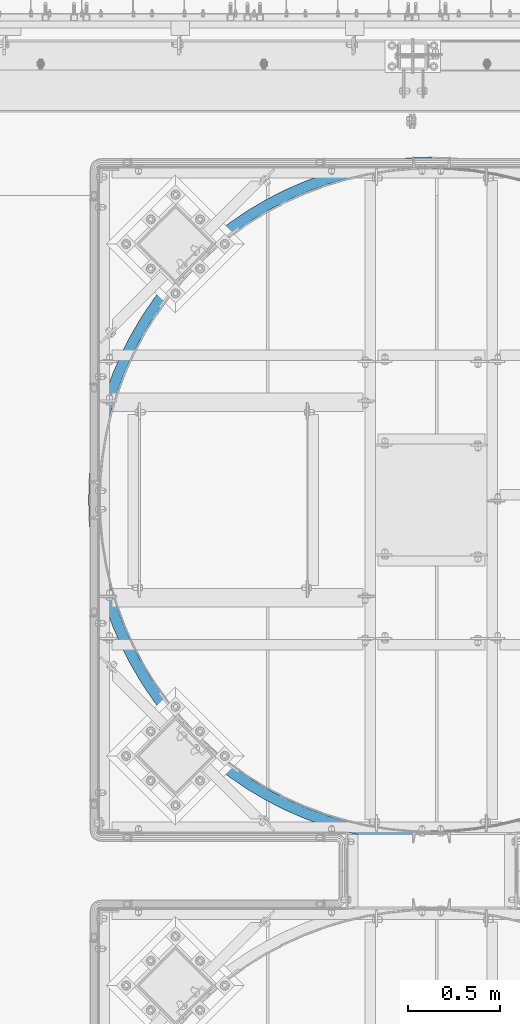
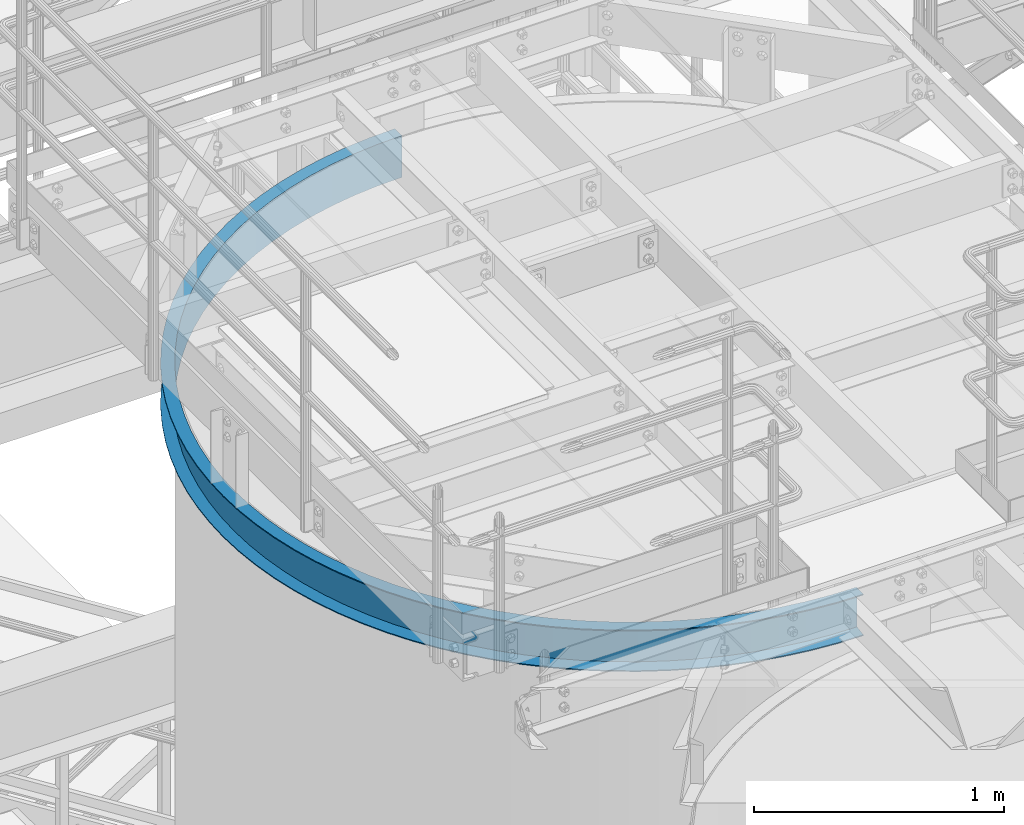
# One storey, part 938 of 1876: 1 beam, 1 element without a shape of its own.
"""IFC2X3 building model written with IfcOpenShell, lengths in millimetres."""

from ifc_helpers import new_model, si_unit, frame, origin_with_axes, place, context, subcontext, project, spatial, faceted_brep, material, type_object, element, aggregate, save


model = new_model("IFC2X3")

# Units and contexts
model_context = context("Model", 3, precision=1e-05, world=origin_with_axes())
body_context = subcontext(model_context, "Body", "Model", "MODEL_VIEW")
ifc_project = project(units=[si_unit("LENGTHUNIT", "METRE", prefix="MILLI"), si_unit("AREAUNIT", "SQUARE_METRE"), si_unit("VOLUMEUNIT", "CUBIC_METRE"), si_unit("MASSUNIT", "GRAM", prefix="KILO"), si_unit("TIMEUNIT", "SECOND"), si_unit("PLANEANGLEUNIT", "RADIAN"), si_unit("SOLIDANGLEUNIT", "STERADIAN"), si_unit("THERMODYNAMICTEMPERATUREUNIT", "DEGREE_CELSIUS"), si_unit("LUMINOUSINTENSITYUNIT", "LUMEN")], contexts=[model_context])

# Site, building, storey
site_placement = place(None, origin_with_axes())
site = spatial("IfcSite", under=ifc_project, at=site_placement, CompositionType="ELEMENT")
building_placement = place(site_placement, origin_with_axes())
building = spatial("IfcBuilding", under=site, at=building_placement, Name="Undefined", CompositionType="ELEMENT")
storey_placement = place(building_placement, origin_with_axes())
storey = spatial("IfcBuildingStorey", under=building, at=storey_placement, Name="Undefined", CompositionType="ELEMENT", Elevation=0.0)

# Assembly, beam
assembly_placement = place(storey_placement, origin_with_axes())
assembly = element("IfcElementAssembly", 1, at=assembly_placement, inside=storey, Name="CHANNEL", AssemblyPlace="NOTDEFINED", PredefinedType="RIGID_FRAME")
ifc_material = material(Name="STEEL/A36")
beam_type = type_object("IfcBeamType", Name="C8X11.5", PredefinedType="NOTDEFINED")
beam_placement = place(assembly_placement, frame((5161.39773816398, -11373.9699317412, 7518.41566278096), z_axis=(0.0, 0.0, -1.0), x_axis=(-0.707106781186548, 0.707106781186547, 0.0)))
beam = element("IfcBeam", 2, at=beam_placement, type_object=beam_type, material=ifc_material, Name="CHANNEL", ObjectType="C8X11.5", context=body_context, shape_type="Brep", body=[
    faceted_brep([(-40.4111525448152, -11.8361525448254, -101.6), (-40.4111525448152, -11.8361525448254, -96.8355949999996), (-4.49012806054634, 24.0848719394708, -88.3723149999996), (-4.49012806054634, 24.0848719394708, 88.3723149999996), (-40.4111525448152, -11.8361525448254, 96.8355949999996), (-40.4111525448152, -11.8361525448254, 101.6), (0.0, 28.5749999999998, 101.6), (0.0, 28.5749999999998, -101.6), (83.1681455805992, -49.5250871930584, 101.6), (83.168145580601, -49.5250871930593, -101.6), (45.3741724773627, -92.3939348224612, -101.6), (45.3741724773627, -92.3939348224612, -96.8355949999996), (78.9688152357958, -54.2882924852147, -88.3723149999996), (78.9688152357958, -54.2882924852147, 88.3723149999996), (45.3741724773627, -92.3939348224612, 96.8355949999996), (45.3741724773627, -92.3939348224612, 101.6), (136.048484757743, -167.406249592315, 96.8355949999996), (136.048484757743, -167.406249592315, 101.6), (167.184163083306, -127.266374963614, 88.3723149999996), (167.184163083306, -127.266374963614, -88.3723149999996), (136.048484757743, -167.406249592315, -96.8355949999996), (136.048484757743, -167.406249592315, -101.6), (171.076122874001, -122.248890635026, 101.6), (171.076122874001, -122.248890635026, -101.6), (231.253934210907, -236.577057517859, 96.8355949999996), (231.253934210907, -236.577057517859, 101.6), (259.807769805786, -194.561364344698, 88.3723149999996), (259.807769805786, -194.561364344698, -88.3723149999996), (231.253934210907, -236.577057517859, -96.8355949999996), (231.253934210907, -236.577057517859, -101.6), (263.376999255146, -189.309402698053, 101.6), (263.376999255146, -189.309402698053, -101.6), (330.614788423094, -299.633373021349, 96.8355949999996), (330.614788423094, -299.633373021349, 101.6), (356.474092343207, -255.907678049534, 88.3723149999996), (356.474092343207, -255.907678049534, -88.3723149999996), (330.614788423094, -299.633373021349, -96.8355949999996), (330.614788423094, -299.633373021349, -101.6), (359.706505333223, -250.441966178058, 101.6), (359.706505333223, -250.441966178058, -101.6), (433.738915496391, -356.326341633181, 96.8355949999996), (433.738915496391, -356.326341633181, 101.6), (456.801632883155, -311.063210204398, 88.3723149999996), (456.801632883155, -311.063210204398, -88.3723149999996), (433.738915496391, -356.326341633181, -96.8355949999996), (433.738915496391, -356.326341633181, -101.6), (459.684472556501, -305.4053187758, 101.6), (459.684472556501, -305.4053187758, -101.6), (540.219331614169, -406.432222106796, 96.8355949999996), (540.219331614169, -406.432222106796, 101.6), (560.39444445841, -359.810287122038, 88.3723149999996), (560.39444445841, -359.810287122038, -88.3723149999996), (540.219331614169, -406.432222106796, -96.8355949999996), (540.219331614169, -406.432222106796, -101.6), (562.91633356394, -353.982545248944, 101.6), (562.91633356394, -353.982545248944, -101.6), (649.635807220287, -449.753269423169, 96.8355949999996), (649.635807220287, -449.753269423169, 101.6), (666.843693568744, -401.956526360284, 88.3723149999996), (666.843693568744, -401.956526360284, -88.3723149999996), (649.635807220287, -449.753269423169, -96.8355949999996), (649.635807220287, -449.753269423169, -101.6), (668.9946793623, -395.981933477424, 101.6), (668.9946793623, -395.981933477424, -101.6), (761.556525473163, -486.118515200043, 96.8355949999996), (761.556525473163, -486.118515200043, 101.6), (775.729273659952, -437.335595967645, 88.3723149999996), (775.729273659952, -437.335595967645, -88.3723149999996), (761.556525473163, -486.118515200043, -96.8355949999996), (761.556525473163, -486.118515200043, -101.6), (777.500867183298, -431.237731063595, 101.6), (777.500867183298, -431.237731063595, -101.6), (875.539786429559, -515.384442426039, 96.8355949999996), (875.539786429559, -515.384442426039, 101.6), (886.621463092501, -465.807870919541, 88.3723149999996), (886.621463092501, -465.807870919541, -88.3723149999996), (875.539786429559, -515.384442426039, -96.8355949999996), (875.539786429559, -515.384442426039, -101.6), (888.006672675367, -459.610799481228, 101.6), (888.006672675367, -459.610799481228, -101.6), (991.135750232484, -537.435551856724, 96.8355949999996), (991.135750232484, -537.435551856724, 101.6), (999.082621056526, -487.260984154484, 88.3723149999996), (999.082621056526, -487.260984154484, -88.3723149999996), (991.135750232484, -537.435551856724, -96.8355949999996), (991.135750232484, -537.435551856724, -101.6), (1000.07597990953, -480.989163191702, 101.6), (1000.07597990953, -480.989163191702, -101.6), (1107.88821242358, -552.184817837371, 96.8355949999996), (1107.88821242358, -552.184817837371, 101.6), (1112.66891474016, -501.610270035526, 88.3723149999996), (1112.66891474016, -501.610270035526, -88.3723149999996), (1107.88821242358, -552.184817837371, -96.8355949999996), (1107.88821242358, -552.184817837371, -101.6), (1113.26650252974, -495.288451560295, 101.6), (1113.26650252974, -495.288451560295, -101.6), (1225.33640437371, -559.574031753455, 96.8355949999996), (1225.33640437371, -559.574031753455, 101.6), (1226.93207093488, -508.799098486866, 88.3723149999996), (1226.93207093488, -508.799098486866, -88.3723149999996), (1225.33640437371, -559.574031753455, -96.8355949999996), (1225.33640437371, -559.574031753455, -101.6), (1227.13152925503, -502.452231828542, 101.6), (1227.13152925503, -502.452231828542, -101.6), (1343.01681172622, -559.574031753454, 96.8355949999996), (1343.01681172622, -559.574031753454, 101.6), (1341.42114516505, -508.799098486867, 88.3723149999996), (1341.42114516505, -508.799098486867, -88.3723149999996), (1343.01681172622, -559.574031753454, -96.8355949999996), (1343.01681172622, -559.574031753454, -101.6), (1341.2216868449, -502.452231828544, 101.6), (1341.2216868449, -502.452231828544, -101.6), (1460.46500367634, -552.184817837373, 96.8355949999996), (1460.46500367634, -552.184817837373, 101.6), (1455.68430135976, -501.610270035527, 88.3723149999996), (1455.68430135976, -501.610270035527, -88.3723149999996), (1460.46500367634, -552.184817837373, -96.8355949999996), (1460.46500367634, -552.184817837373, -101.6), (1455.08671357019, -495.288451560297, 101.6), (1455.08671357019, -495.288451560297, -101.6), (1577.21746586744, -537.435551856726, 96.8355949999996), (1577.21746586744, -537.435551856726, 101.6), (1569.2705950434, -487.260984154484, 88.3723149999996), (1569.2705950434, -487.260984154484, -88.3723149999996), (1577.21746586744, -537.435551856726, -96.8355949999996), (1577.21746586744, -537.435551856726, -101.6), (1568.27723619039, -480.989163191705, 101.6), (1568.27723619039, -480.989163191705, -101.6), (1692.81342967037, -515.384442426042, 96.8355949999996), (1692.81342967037, -515.384442426042, 101.6), (1681.73175300743, -465.807870919543, 88.3723149999996), (1681.73175300743, -465.807870919543, -88.3723149999996), (1692.81342967037, -515.384442426042, -96.8355949999996), (1692.81342967037, -515.384442426042, -101.6), (1680.34654342456, -459.610799481231, 101.6), (1680.34654342456, -459.610799481231, -101.6), (1806.79669062676, -486.118515200047, 96.8355949999996), (1806.79669062676, -486.118515200047, 101.6), (1792.62394243998, -437.335595967647, 88.3723149999996), (1792.62394243998, -437.335595967647, -88.3723149999996), (1806.79669062676, -486.118515200047, -96.8355949999996), (1806.79669062676, -486.118515200047, -101.6), (1790.85234891663, -431.237731063598, 101.6), (1790.85234891663, -431.237731063598, -101.6), (1918.71740887964, -449.753269423174, 96.8355949999996), (1918.71740887964, -449.753269423174, 101.6), (1901.50952253118, -401.956526360288, 88.3723149999996), (1901.50952253118, -401.956526360288, -88.3723149999996), (1918.71740887964, -449.753269423174, -96.8355949999996), (1918.71740887964, -449.753269423174, -101.6), (1899.35853673763, -395.981933477428, 101.6), (1899.35853673763, -395.981933477428, -101.6), (2028.13388448576, -406.432222106803, 96.8355949999996), (2028.13388448576, -406.432222106803, 101.6), (2007.95877164152, -359.810287122044, 88.3723149999996), (2007.95877164152, -359.810287122044, -88.3723149999996), (2028.13388448576, -406.432222106803, -96.8355949999996), (2028.13388448576, -406.432222106803, -101.6), (2005.43688253599, -353.982545248949, 101.6), (2005.43688253599, -353.982545248949, -101.6), (2134.61430060353, -356.326341633187, 96.8355949999996), (2134.61430060353, -356.326341633187, 101.6), (2111.55158321677, -311.063210204405, 88.3723149999996), (2111.55158321677, -311.063210204405, -88.3723149999996), (2134.61430060353, -356.326341633187, -96.8355949999996), (2134.61430060353, -356.326341633187, -101.6), (2108.66874354343, -305.405318775807, 101.6), (2108.66874354343, -305.405318775807, -101.6), (2237.73842767683, -299.633373021357, 96.8355949999996), (2237.73842767683, -299.633373021357, 101.6), (2211.87912375672, -255.907678049542, 88.3723149999996), (2211.87912375672, -255.907678049542, -88.3723149999996), (2237.73842767683, -299.633373021357, -96.8355949999996), (2237.73842767683, -299.633373021357, -101.6), (2208.64671076671, -250.441966178065, 101.6), (2208.64671076671, -250.441966178065, -101.6), (2337.09928188902, -236.577057517868, 96.8355949999996), (2337.09928188902, -236.577057517868, 101.6), (2308.54544629414, -194.561364344705, 88.3723149999996), (2308.54544629414, -194.561364344705, -88.3723149999996), (2337.09928188902, -236.577057517868, -96.8355949999996), (2337.09928188902, -236.577057517868, -101.6), (2304.97621684478, -189.30940269806, 101.6), (2304.97621684478, -189.30940269806, -101.6), (2432.30473134219, -167.406249592324, 96.8355949999996), (2432.30473134219, -167.406249592324, 101.6), (2401.16905301662, -127.266374963622, 88.3723149999996), (2401.16905301662, -127.266374963622, -88.3723149999996), (2432.30473134219, -167.406249592324, -96.8355949999996), (2432.30473134219, -167.406249592324, -101.6), (2397.27709322593, -122.248890635034, 101.6), (2397.27709322593, -122.248890635034, -101.6), (2522.97904362256, -92.3939348224685, 96.8355949999996), (2522.97904362256, -92.3939348224685, 101.6), (2489.38440086413, -54.2882924852247, 88.3723149999996), (2489.38440086413, -54.2882924852247, -88.3723149999996), (2522.97904362256, -92.3939348224685, -96.8355949999996), (2522.97904362256, -92.3939348224685, -101.6), (2485.18507051933, -49.5250871930684, 101.6), (2485.18507051933, -49.5250871930684, -101.6), (2608.76436864474, -11.8361525448345, 96.8355949999996), (2608.76436864474, -11.8361525448345, 101.6), (2572.84334416047, 24.0848719394626, 88.3723149999996), (2572.84334416047, 24.0848719394626, -88.3723149999996), (2608.76436864474, -11.8361525448345, -96.8355949999996), (2608.76436864474, -11.8361525448345, -101.6), (2568.35321609994, 28.5749999999989, 101.6), (2568.35321609993, 28.5749999999989, -101.6), (2764.3344656923, 164.623484757718, 101.6), (2833.50527361787, 259.828934210873, 101.6), (2896.56158912139, 359.189788423056, 101.6), (2953.25455773324, 462.313915496351, 101.6), (3003.36043820688, 568.794331614128, 101.6), (3046.68148552328, 678.210807220248, 101.6), (3083.04673130017, 790.131525473126, 101.6), (3112.31265852618, 904.114786429529, 101.6), (3134.36376795688, 1019.71075023246, 101.6), (3149.11303393754, 1136.46321242357, 101.6), (3156.50224785364, 1253.91140437371, 101.6), (3156.50224785364, 1371.59181172622, 101.6), (3149.11303393757, 1489.04000367636, 101.6), (3134.36376795692, 1605.79246586747, 101.6), (3112.31265852624, 1721.38842967041, 101.6), (3083.04673130024, 1835.37169062681, 101.6), (3046.68148552336, 1947.2924088797, 101.6), (3003.36043820698, 2056.70888448582, 101.6), (2953.25455773336, 2163.18930060361, 101.6), (2896.56158912152, 2266.31342767691, 101.6), (2833.50527361802, 2365.67428188911, 101.6), (2764.33446569245, 2460.87973134227, 101.6), (2689.32215092258, 2551.55404362265, 101.6), (2608.76436864493, 2637.33936864483, 101.6), (2568.3532161001, 2596.92821610002, 101.6), (2646.45330329319, 2513.76007051941, 101.6), (2719.17710673517, 2425.85209322601, 101.6), (2786.23761879821, 2333.55121684486, 101.6), (2847.37018227823, 2237.22171076678, 101.6), (2902.33353487598, 2137.2437435435, 101.6), (2950.91076134913, 2034.01188253605, 101.6), (2992.91014957762, 1927.93353673768, 101.6), (3028.16594716379, 1819.42734891668, 101.6), (3056.53901558143, 1708.9215434246, 101.6), (3077.9173792919, 1596.85223619042, 101.6), (3092.21666766049, 1483.66171357021, 101.6), (3099.38044792873, 1369.79668684491, 101.6), (3099.38044792872, 1255.70652925503, 101.6), (3092.21666766047, 1141.84150252973, 101.6), (3077.91737929186, 1028.65097990952, 101.6), (3056.53901558137, 916.581672675346, 101.6), (3028.16594716372, 806.075867183273, 101.6), (2992.91014957753, 697.569679362271, 101.6), (2950.91076134903, 591.49133356391, 101.6), (2902.33353487587, 488.25947255647, 101.6), (2847.3701822781, 388.281505333194, 101.6), (2786.23761879807, 291.951999255124, 101.6), (2719.17710673502, 199.651122873987, 101.6), (2646.45330329302, 111.743145580598, 101.6), (2689.32215092242, 73.9491724773488, 101.6), (2646.45330329302, 111.743145580598, -101.6), (2719.17710673502, 199.651122873987, -101.6), (2786.23761879807, 291.951999255124, -101.6), (2847.3701822781, 388.281505333194, -101.6), (2902.33353487587, 488.25947255647, -101.6), (2950.91076134903, 591.49133356391, -101.6), (2992.91014957753, 697.569679362271, -101.6), (3028.16594716372, 806.075867183273, -101.6), (3056.53901558137, 916.581672675346, -101.6), (3077.91737929186, 1028.65097990952, -101.6), (3092.21666766047, 1141.84150252973, -101.6), (3099.38044792872, 1255.70652925503, -101.6), (3099.38044792873, 1369.79668684491, -101.6), (3092.21666766049, 1483.66171357021, -101.6), (3077.9173792919, 1596.85223619042, -101.6), (3056.53901558143, 1708.9215434246, -101.6), (3028.16594716379, 1819.42734891668, -101.6), (2992.91014957762, 1927.93353673768, -101.6), (2950.91076134913, 2034.01188253605, -101.6), (2902.33353487598, 2137.2437435435, -101.6), (2847.37018227823, 2237.22171076678, -101.6), (2786.23761879821, 2333.55121684486, -101.6), (2719.17710673517, 2425.85209322601, -101.6), (2646.45330329319, 2513.76007051941, -101.6), (2568.3532161001, 2596.92821610002, -101.6), (2608.76436864493, 2637.33936864483, -101.6), (2689.32215092258, 2551.55404362265, -101.6), (2764.33446569245, 2460.87973134227, -101.6), (2833.50527361802, 2365.67428188911, -101.6), (2896.56158912152, 2266.31342767691, -101.6), (2953.25455773336, 2163.18930060361, -101.6), (3003.36043820698, 2056.70888448582, -101.6), (3046.68148552336, 1947.2924088797, -101.6), (3083.04673130024, 1835.37169062681, -101.6), (3112.31265852624, 1721.38842967041, -101.6), (3134.36376795692, 1605.79246586747, -101.6), (3149.11303393757, 1489.04000367636, -101.6), (3156.50224785364, 1371.59181172622, -101.6), (3156.50224785364, 1253.91140437371, -101.6), (3149.11303393754, 1136.46321242357, -101.6), (3134.36376795688, 1019.71075023246, -101.6), (3112.31265852618, 904.114786429529, -101.6), (3083.04673130017, 790.131525473126, -101.6), (3046.68148552328, 678.210807220248, -101.6), (3003.36043820688, 568.794331614128, -101.6), (2953.25455773324, 462.313915496351, -101.6), (2896.56158912139, 359.189788423056, -101.6), (2833.50527361787, 259.828934210873, -101.6), (2764.3344656923, 164.623484757718, -101.6), (2689.32215092242, 73.9491724773488, -101.6), (2689.32215092242, 73.9491724773488, -96.8355949999996), (2651.21650858518, 107.543815235792, -88.3723149999996), (2651.21650858518, 107.543815235792, 88.3723149999996), (2689.32215092242, 73.9491724773488, 96.8355949999996), (2764.3344656923, 164.623484757718, 96.8355949999996), (2724.19459106361, 195.75916308329, 88.3723149999996), (2724.19459106361, 195.75916308329, -88.3723149999996), (2764.3344656923, 164.623484757718, -96.8355949999996), (2833.50527361787, 259.828934210873, 96.8355949999996), (2791.48958044472, 288.382769805763, 88.3723149999996), (2791.48958044472, 288.382769805763, -88.3723149999996), (2833.50527361787, 259.828934210873, -96.8355949999996), (2896.56158912139, 359.189788423056, 96.8355949999996), (2852.83589414958, 385.049092343178, 88.3723149999996), (2852.83589414958, 385.049092343178, -88.3723149999996), (2896.56158912139, 359.189788423056, -96.8355949999996), (2953.25455773324, 462.313915496351, 96.8355949999996), (2907.99142630447, 485.376632883123, 88.3723149999996), (2907.99142630447, 485.376632883123, -88.3723149999996), (2953.25455773324, 462.313915496351, -96.8355949999996), (3003.36043820688, 568.794331614128, 96.8355949999996), (2956.73850322213, 588.969444458379, 88.3723149999996), (2956.73850322213, 588.969444458379, -88.3723149999996), (3003.36043820688, 568.794331614128, -96.8355949999996), (3046.68148552328, 678.210807220248, 96.8355949999996), (2998.88474246039, 695.418693568713, 88.3723149999996), (2998.88474246039, 695.418693568713, -88.3723149999996), (3046.68148552328, 678.210807220248, -96.8355949999996), (3083.04673130017, 790.131525473126, 96.8355949999996), (3034.26381206777, 804.304273659922, 88.3723149999996), (3034.26381206777, 804.304273659922, -88.3723149999996), (3083.04673130017, 790.131525473126, -96.8355949999996), (3112.31265852618, 904.114786429529, 96.8355949999996), (3062.73608701968, 915.196463092477, 88.3723149999996), (3062.73608701968, 915.196463092477, -88.3723149999996), (3112.31265852618, 904.114786429529, -96.8355949999996), (3134.36376795688, 1019.71075023246, 96.8355949999996), (3084.18920025464, 1027.65762105651, 88.3723149999996), (3084.18920025464, 1027.65762105651, -88.3723149999996), (3134.36376795688, 1019.71075023246, -96.8355949999996), (3149.11303393754, 1136.46321242357, 96.8355949999996), (3098.5384861357, 1141.24391474015, 88.3723149999996), (3098.5384861357, 1141.24391474015, -88.3723149999996), (3149.11303393754, 1136.46321242357, -96.8355949999996), (3156.50224785364, 1253.91140437371, 96.8355949999996), (3105.72731458705, 1255.50707093488, 88.3723149999996), (3105.72731458705, 1255.50707093488, -88.3723149999996), (3156.50224785364, 1253.91140437371, -96.8355949999996), (3156.50224785364, 1371.59181172622, 96.8355949999996), (3105.72731458705, 1369.99614516506, 88.3723149999996), (3105.72731458705, 1369.99614516506, -88.3723149999996), (3156.50224785364, 1371.59181172622, -96.8355949999996), (3149.11303393757, 1489.04000367636, 96.8355949999996), (3098.53848613572, 1484.25930135978, 88.3723149999996), (3098.53848613572, 1484.25930135978, -88.3723149999996), (3149.11303393757, 1489.04000367636, -96.8355949999996), (3134.36376795692, 1605.79246586747, 96.8355949999996), (3084.18920025468, 1597.84559504343, 88.3723149999996), (3084.18920025468, 1597.84559504343, -88.3723149999996), (3134.36376795692, 1605.79246586747, -96.8355949999996), (3112.31265852624, 1721.38842967041, 96.8355949999996), (3062.73608701974, 1710.30675300747, 88.3723149999996), (3062.73608701974, 1710.30675300747, -88.3723149999996), (3112.31265852624, 1721.38842967041, -96.8355949999996), (3083.04673130024, 1835.37169062681, 96.8355949999996), (3034.26381206784, 1821.19894244003, 88.3723149999996), (3034.26381206784, 1821.19894244003, -88.3723149999996), (3083.04673130024, 1835.37169062681, -96.8355949999996), (3046.68148552336, 1947.2924088797, 96.8355949999996), (2998.88474246048, 1930.08452253124, 88.3723149999996), (2998.88474246048, 1930.08452253124, -88.3723149999996), (3046.68148552336, 1947.2924088797, -96.8355949999996), (3003.36043820698, 2056.70888448582, 96.8355949999996), (2956.73850322223, 2036.53377164158, 88.3723149999996), (2956.73850322223, 2036.53377164158, -88.3723149999996), (3003.36043820698, 2056.70888448582, -96.8355949999996), (2953.25455773336, 2163.18930060361, 96.8355949999996), (2907.99142630458, 2140.12658321685, 88.3723149999996), (2907.99142630458, 2140.12658321685, -88.3723149999996), (2953.25455773336, 2163.18930060361, -96.8355949999996), (2896.56158912152, 2266.31342767691, 96.8355949999996), (2852.8358941497, 2240.4541237568, 88.3723149999996), (2852.8358941497, 2240.4541237568, -88.3723149999996), (2896.56158912152, 2266.31342767691, -96.8355949999996), (2833.50527361802, 2365.67428188911, 96.8355949999996), (2791.48958044486, 2337.12044629422, 88.3723149999996), (2791.48958044486, 2337.12044629422, -88.3723149999996), (2833.50527361802, 2365.67428188911, -96.8355949999996), (2764.33446569245, 2460.87973134227, 96.8355949999996), (2724.19459106376, 2429.74405301671, 88.3723149999996), (2724.19459106376, 2429.74405301671, -88.3723149999996), (2764.33446569245, 2460.87973134227, -96.8355949999996), (2689.32215092258, 2551.55404362265, 96.8355949999996), (2651.21650858534, 2517.95940086422, 88.3723149999996), (2651.21650858534, 2517.95940086422, -88.3723149999996), (2689.32215092258, 2551.55404362265, -96.8355949999996), (2608.76436864493, 2637.33936864483, 96.8355949999996), (2572.84334416064, 2601.41834416056, 88.3723149999996), (2572.84334416064, 2601.41834416056, -88.3723149999996), (2608.76436864493, 2637.33936864483, -96.8355949999996)], [[[0, 1, 2, 3, 4, 5, 6, 7]], [[7, 6, 8, 9]], [[1, 0, 10, 11]], [[2, 1, 11, 12]], [[3, 2, 12, 13]], [[4, 3, 13, 14]], [[5, 4, 14, 15]], [[14, 16, 17, 15]], [[13, 18, 16, 14]], [[12, 19, 18, 13]], [[11, 20, 19, 12]], [[10, 21, 20, 11]], [[8, 22, 23, 9]], [[16, 24, 25, 17]], [[18, 26, 24, 16]], [[19, 27, 26, 18]], [[20, 28, 27, 19]], [[21, 29, 28, 20]], [[22, 30, 31, 23]], [[24, 32, 33, 25]], [[26, 34, 32, 24]], [[27, 35, 34, 26]], [[28, 36, 35, 27]], [[29, 37, 36, 28]], [[30, 38, 39, 31]], [[32, 40, 41, 33]], [[34, 42, 40, 32]], [[35, 43, 42, 34]], [[36, 44, 43, 35]], [[37, 45, 44, 36]], [[38, 46, 47, 39]], [[40, 48, 49, 41]], [[42, 50, 48, 40]], [[43, 51, 50, 42]], [[44, 52, 51, 43]], [[45, 53, 52, 44]], [[46, 54, 55, 47]], [[48, 56, 57, 49]], [[50, 58, 56, 48]], [[51, 59, 58, 50]], [[52, 60, 59, 51]], [[53, 61, 60, 52]], [[54, 62, 63, 55]], [[56, 64, 65, 57]], [[58, 66, 64, 56]], [[59, 67, 66, 58]], [[60, 68, 67, 59]], [[61, 69, 68, 60]], [[62, 70, 71, 63]], [[64, 72, 73, 65]], [[66, 74, 72, 64]], [[67, 75, 74, 66]], [[68, 76, 75, 67]], [[69, 77, 76, 68]], [[70, 78, 79, 71]], [[72, 80, 81, 73]], [[74, 82, 80, 72]], [[75, 83, 82, 74]], [[76, 84, 83, 75]], [[77, 85, 84, 76]], [[78, 86, 87, 79]], [[80, 88, 89, 81]], [[82, 90, 88, 80]], [[83, 91, 90, 82]], [[84, 92, 91, 83]], [[85, 93, 92, 84]], [[86, 94, 95, 87]], [[88, 96, 97, 89]], [[90, 98, 96, 88]], [[91, 99, 98, 90]], [[92, 100, 99, 91]], [[93, 101, 100, 92]], [[94, 102, 103, 95]], [[96, 104, 105, 97]], [[98, 106, 104, 96]], [[99, 107, 106, 98]], [[100, 108, 107, 99]], [[101, 109, 108, 100]], [[102, 110, 111, 103]], [[104, 112, 113, 105]], [[106, 114, 112, 104]], [[107, 115, 114, 106]], [[108, 116, 115, 107]], [[109, 117, 116, 108]], [[110, 118, 119, 111]], [[112, 120, 121, 113]], [[114, 122, 120, 112]], [[115, 123, 122, 114]], [[116, 124, 123, 115]], [[117, 125, 124, 116]], [[118, 126, 127, 119]], [[120, 128, 129, 121]], [[122, 130, 128, 120]], [[123, 131, 130, 122]], [[124, 132, 131, 123]], [[125, 133, 132, 124]], [[126, 134, 135, 127]], [[128, 136, 137, 129]], [[130, 138, 136, 128]], [[131, 139, 138, 130]], [[132, 140, 139, 131]], [[133, 141, 140, 132]], [[134, 142, 143, 135]], [[136, 144, 145, 137]], [[138, 146, 144, 136]], [[139, 147, 146, 138]], [[140, 148, 147, 139]], [[141, 149, 148, 140]], [[142, 150, 151, 143]], [[144, 152, 153, 145]], [[146, 154, 152, 144]], [[147, 155, 154, 146]], [[148, 156, 155, 147]], [[149, 157, 156, 148]], [[150, 158, 159, 151]], [[152, 160, 161, 153]], [[154, 162, 160, 152]], [[155, 163, 162, 154]], [[156, 164, 163, 155]], [[157, 165, 164, 156]], [[158, 166, 167, 159]], [[160, 168, 169, 161]], [[162, 170, 168, 160]], [[163, 171, 170, 162]], [[164, 172, 171, 163]], [[165, 173, 172, 164]], [[166, 174, 175, 167]], [[168, 176, 177, 169]], [[170, 178, 176, 168]], [[171, 179, 178, 170]], [[172, 180, 179, 171]], [[173, 181, 180, 172]], [[174, 182, 183, 175]], [[176, 184, 185, 177]], [[178, 186, 184, 176]], [[179, 187, 186, 178]], [[180, 188, 187, 179]], [[181, 189, 188, 180]], [[182, 190, 191, 183]], [[184, 192, 193, 185]], [[186, 194, 192, 184]], [[187, 195, 194, 186]], [[188, 196, 195, 187]], [[189, 197, 196, 188]], [[190, 198, 199, 191]], [[192, 200, 201, 193]], [[194, 202, 200, 192]], [[195, 203, 202, 194]], [[196, 204, 203, 195]], [[197, 205, 204, 196]], [[198, 206, 207, 199]], [[208, 209, 210, 211, 212, 213, 214, 215, 216, 217, 218, 219, 220, 221, 222, 223, 224, 225, 226, 227, 228, 229, 230, 231, 232, 233, 234, 235, 236, 237, 238, 239, 240, 241, 242, 243, 244, 245, 246, 247, 248, 249, 250, 251, 252, 253, 254, 255, 256, 206, 198, 190, 182, 174, 166, 158, 150, 142, 134, 126, 118, 110, 102, 94, 86, 78, 70, 62, 54, 46, 38, 30, 22, 8, 6, 5, 15, 17, 25, 33, 41, 49, 57, 65, 73, 81, 89, 97, 105, 113, 121, 129, 137, 145, 153, 161, 169, 177, 185, 193, 201, 257]], [[207, 206, 256, 258]], [[259, 260, 261, 262, 263, 264, 265, 266, 267, 268, 269, 270, 271, 272, 273, 274, 275, 276, 277, 278, 279, 280, 281, 282, 283, 284, 285, 286, 287, 288, 289, 290, 291, 292, 293, 294, 295, 296, 297, 298, 299, 300, 301, 302, 303, 304, 305, 306, 307, 205, 197, 189, 181, 173, 165, 157, 149, 141, 133, 125, 117, 109, 101, 93, 85, 77, 69, 61, 53, 45, 37, 29, 21, 10, 0, 7, 9, 23, 31, 39, 47, 55, 63, 71, 79, 87, 95, 103, 111, 119, 127, 135, 143, 151, 159, 167, 175, 183, 191, 199, 207, 258]], [[204, 205, 307, 308]], [[203, 204, 308, 309]], [[202, 203, 309, 310]], [[200, 202, 310, 311]], [[201, 200, 311, 257]], [[311, 312, 208, 257]], [[310, 313, 312, 311]], [[309, 314, 313, 310]], [[308, 315, 314, 309]], [[307, 306, 315, 308]], [[256, 255, 259, 258]], [[312, 316, 209, 208]], [[313, 317, 316, 312]], [[314, 318, 317, 313]], [[315, 319, 318, 314]], [[306, 305, 319, 315]], [[255, 254, 260, 259]], [[316, 320, 210, 209]], [[317, 321, 320, 316]], [[318, 322, 321, 317]], [[319, 323, 322, 318]], [[305, 304, 323, 319]], [[254, 253, 261, 260]], [[320, 324, 211, 210]], [[321, 325, 324, 320]], [[322, 326, 325, 321]], [[323, 327, 326, 322]], [[304, 303, 327, 323]], [[253, 252, 262, 261]], [[324, 328, 212, 211]], [[325, 329, 328, 324]], [[326, 330, 329, 325]], [[327, 331, 330, 326]], [[303, 302, 331, 327]], [[252, 251, 263, 262]], [[328, 332, 213, 212]], [[329, 333, 332, 328]], [[330, 334, 333, 329]], [[331, 335, 334, 330]], [[302, 301, 335, 331]], [[251, 250, 264, 263]], [[332, 336, 214, 213]], [[333, 337, 336, 332]], [[334, 338, 337, 333]], [[335, 339, 338, 334]], [[301, 300, 339, 335]], [[250, 249, 265, 264]], [[336, 340, 215, 214]], [[337, 341, 340, 336]], [[338, 342, 341, 337]], [[339, 343, 342, 338]], [[300, 299, 343, 339]], [[249, 248, 266, 265]], [[340, 344, 216, 215]], [[341, 345, 344, 340]], [[342, 346, 345, 341]], [[343, 347, 346, 342]], [[299, 298, 347, 343]], [[248, 247, 267, 266]], [[344, 348, 217, 216]], [[345, 349, 348, 344]], [[346, 350, 349, 345]], [[347, 351, 350, 346]], [[298, 297, 351, 347]], [[247, 246, 268, 267]], [[348, 352, 218, 217]], [[349, 353, 352, 348]], [[350, 354, 353, 349]], [[351, 355, 354, 350]], [[297, 296, 355, 351]], [[246, 245, 269, 268]], [[352, 356, 219, 218]], [[353, 357, 356, 352]], [[354, 358, 357, 353]], [[355, 359, 358, 354]], [[296, 295, 359, 355]], [[245, 244, 270, 269]], [[356, 360, 220, 219]], [[357, 361, 360, 356]], [[358, 362, 361, 357]], [[359, 363, 362, 358]], [[295, 294, 363, 359]], [[244, 243, 271, 270]], [[360, 364, 221, 220]], [[361, 365, 364, 360]], [[362, 366, 365, 361]], [[363, 367, 366, 362]], [[294, 293, 367, 363]], [[243, 242, 272, 271]], [[364, 368, 222, 221]], [[365, 369, 368, 364]], [[366, 370, 369, 365]], [[367, 371, 370, 366]], [[293, 292, 371, 367]], [[242, 241, 273, 272]], [[368, 372, 223, 222]], [[369, 373, 372, 368]], [[370, 374, 373, 369]], [[371, 375, 374, 370]], [[292, 291, 375, 371]], [[241, 240, 274, 273]], [[372, 376, 224, 223]], [[373, 377, 376, 372]], [[374, 378, 377, 373]], [[375, 379, 378, 374]], [[291, 290, 379, 375]], [[240, 239, 275, 274]], [[376, 380, 225, 224]], [[377, 381, 380, 376]], [[378, 382, 381, 377]], [[379, 383, 382, 378]], [[290, 289, 383, 379]], [[239, 238, 276, 275]], [[380, 384, 226, 225]], [[381, 385, 384, 380]], [[382, 386, 385, 381]], [[383, 387, 386, 382]], [[289, 288, 387, 383]], [[238, 237, 277, 276]], [[384, 388, 227, 226]], [[385, 389, 388, 384]], [[386, 390, 389, 385]], [[387, 391, 390, 386]], [[288, 287, 391, 387]], [[237, 236, 278, 277]], [[388, 392, 228, 227]], [[389, 393, 392, 388]], [[390, 394, 393, 389]], [[391, 395, 394, 390]], [[287, 286, 395, 391]], [[236, 235, 279, 278]], [[392, 396, 229, 228]], [[393, 397, 396, 392]], [[394, 398, 397, 393]], [[395, 399, 398, 394]], [[286, 285, 399, 395]], [[235, 234, 280, 279]], [[396, 400, 230, 229]], [[397, 401, 400, 396]], [[398, 402, 401, 397]], [[399, 403, 402, 398]], [[285, 284, 403, 399]], [[234, 233, 281, 280]], [[231, 404, 405, 406, 407, 283, 282, 232]], [[400, 404, 231, 230]], [[401, 405, 404, 400]], [[402, 406, 405, 401]], [[403, 407, 406, 402]], [[284, 283, 407, 403]], [[233, 232, 282, 281]]]),
])
aggregate(assembly, [beam])

save(model, "model.ifc")
